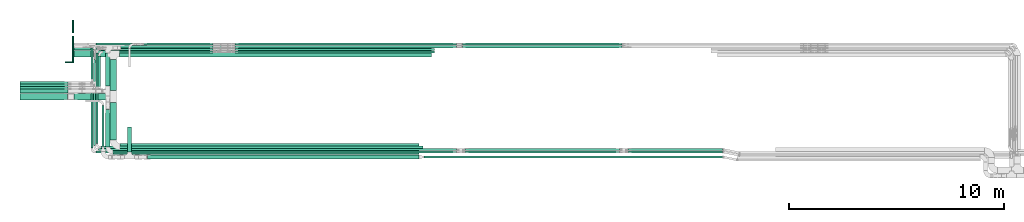
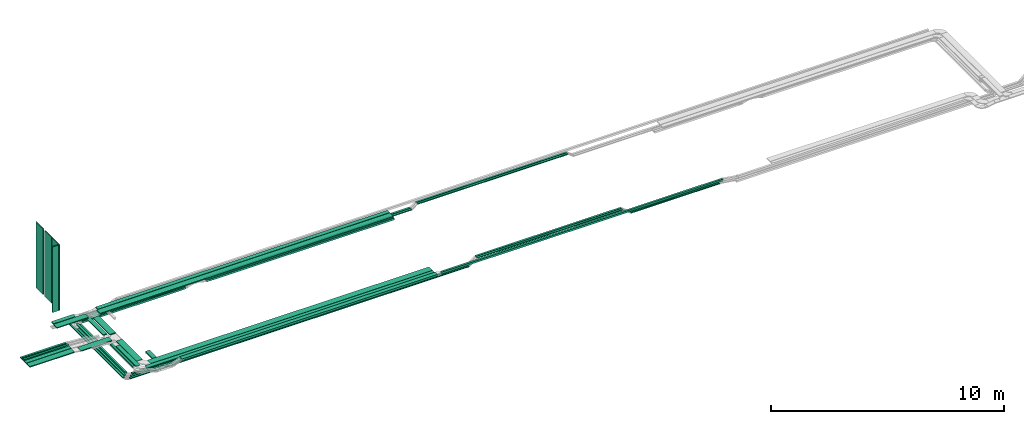
# One storey, part 1 of 19: 47 flow segments.
"""IFC2X3 building model written with IfcOpenShell, lengths in millimetres."""

from ifc_helpers import new_model, entity, si_unit, converted_unit, derived_unit, direction, frame, origin, origin_2d_with_axis, place, context, subcontext, project, spatial, rectangle, extrude, type_object, element, save


model = new_model("IFC2X3")

# Units and contexts
model_context = context("Model", 3, precision=0.01, world=origin(), true_north=direction((6.12303176911189e-17, 1.0)))
body_context = subcontext(model_context, "Body", "Model", "MODEL_VIEW")
ifc_project = project(units=[si_unit("LENGTHUNIT", "METRE", prefix="MILLI"), si_unit("AREAUNIT", "SQUARE_METRE"), si_unit("VOLUMEUNIT", "CUBIC_METRE"), converted_unit("PLANEANGLEUNIT", "DEGREE", entity("IfcRatioMeasure", 0.0174532925199433), si_unit("PLANEANGLEUNIT", "RADIAN"), dimensions=[0, 0, 0, 0, 0, 0, 0]), si_unit("MASSUNIT", "GRAM", prefix="KILO"), derived_unit("MASSDENSITYUNIT", [(si_unit("MASSUNIT", "GRAM", prefix="KILO"), 1), (si_unit("LENGTHUNIT", "METRE"), -3)]), derived_unit("MOMENTOFINERTIAUNIT", [(si_unit("LENGTHUNIT", "METRE"), 4)]), si_unit("TIMEUNIT", "SECOND"), si_unit("FREQUENCYUNIT", "HERTZ"), si_unit("THERMODYNAMICTEMPERATUREUNIT", "DEGREE_CELSIUS"), derived_unit("THERMALTRANSMITTANCEUNIT", [(si_unit("MASSUNIT", "GRAM", prefix="KILO"), 1), (si_unit("THERMODYNAMICTEMPERATUREUNIT", "KELVIN"), -1), (si_unit("TIMEUNIT", "SECOND"), -3)]), derived_unit("VOLUMETRICFLOWRATEUNIT", [(si_unit("LENGTHUNIT", "METRE"), 3), (si_unit("TIMEUNIT", "SECOND"), -1)]), derived_unit("MASSFLOWRATEUNIT", [(si_unit("MASSUNIT", "GRAM", prefix="KILO"), 1), (si_unit("TIMEUNIT", "SECOND"), -1)]), derived_unit("ROTATIONALFREQUENCYUNIT", [(si_unit("TIMEUNIT", "SECOND"), -1)]), si_unit("ELECTRICCURRENTUNIT", "AMPERE"), si_unit("ELECTRICVOLTAGEUNIT", "VOLT"), si_unit("POWERUNIT", "WATT"), si_unit("FORCEUNIT", "NEWTON", prefix="KILO"), si_unit("ILLUMINANCEUNIT", "LUX"), si_unit("LUMINOUSFLUXUNIT", "LUMEN"), si_unit("LUMINOUSINTENSITYUNIT", "CANDELA"), derived_unit("USERDEFINED", [(si_unit("MASSUNIT", "GRAM", prefix="KILO"), -1), (si_unit("LENGTHUNIT", "METRE"), -2), (si_unit("TIMEUNIT", "SECOND"), 3), (si_unit("LUMINOUSFLUXUNIT", "LUMEN"), 1)]), derived_unit("LINEARVELOCITYUNIT", [(si_unit("LENGTHUNIT", "METRE"), 1), (si_unit("TIMEUNIT", "SECOND"), -1)]), si_unit("PRESSUREUNIT", "PASCAL"), derived_unit("USERDEFINED", [(si_unit("LENGTHUNIT", "METRE"), -2), (si_unit("MASSUNIT", "GRAM", prefix="KILO"), 1), (si_unit("TIMEUNIT", "SECOND"), -2)]), derived_unit("LINEARFORCEUNIT", [(si_unit("MASSUNIT", "GRAM", prefix="KILO"), 1), (si_unit("LENGTHUNIT", "METRE"), 1), (si_unit("TIMEUNIT", "SECOND"), -2), (si_unit("LENGTHUNIT", "METRE"), -1)]), derived_unit("PLANARFORCEUNIT", [(si_unit("MASSUNIT", "GRAM", prefix="KILO"), 1), (si_unit("LENGTHUNIT", "METRE"), 1), (si_unit("TIMEUNIT", "SECOND"), -2), (si_unit("LENGTHUNIT", "METRE"), -2)])], contexts=[model_context])

# Site, building, storey
site_placement = place(None, origin())
site = spatial("IfcSite", under=ifc_project, at=site_placement, CompositionType="ELEMENT")
building_placement = place(site_placement, origin())
building = spatial("IfcBuilding", under=site, at=building_placement, CompositionType="ELEMENT")
storey_placement = place(building_placement, frame((0.0, 0.0, 12000.0)))
storey = spatial("IfcBuildingStorey", under=building, at=storey_placement, CompositionType="ELEMENT", Elevation=12000.0)

# Flow segments
cable_carrier_segment_type_1 = type_object("IfcCableCarrierSegmentType", PredefinedType="CABLETRAYSEGMENT")
flow_segment_1_placement = place(storey_placement, frame((18658.54, 14255.0, 2800.0)))
element("IfcFlowSegment", 1, at=flow_segment_1_placement, inside=storey, type_object=cable_carrier_segment_type_1, context=body_context, shape_type="SweptSolid", body=[
    extrude(rectangle(XDim=14526.5501481174, YDim=300.000000000001, at=origin_2d_with_axis()), frame((7263.28, 150.0, 0.0)), (0.0, 0.0, 1.0), 50.0000000000016),
])
flow_segment_2_placement = place(storey_placement, frame((18739.07, 14572.5, 2800.0)))
element("IfcFlowSegment", 2, at=flow_segment_2_placement, inside=storey, type_object=cable_carrier_segment_type_1, context=body_context, shape_type="SweptSolid", body=[
    extrude(rectangle(XDim=14446.0157179897, YDim=200.000000000002, at=origin_2d_with_axis()), frame((7223.01, 100.0, 0.0)), (0.0, 0.0, 1.0), 50.0000000000016),
])
flow_segment_3_placement = place(storey_placement, frame((18679.54, 9924.94, 2800.0)))
element("IfcFlowSegment", 3, at=flow_segment_3_placement, inside=storey, type_object=cable_carrier_segment_type_1, context=body_context, shape_type="SweptSolid", body=[
    extrude(rectangle(XDim=13925.5501481174, YDim=300.000000000001, at=origin_2d_with_axis()), frame((6962.78, 150.0, 0.0)), (0.0, 0.0, 1.0), 50.0000000000016),
])
flow_segment_4_placement = place(storey_placement, frame((18369.59, 9713.18, 2800.81)))
element("IfcFlowSegment", 4, at=flow_segment_4_placement, inside=storey, type_object=cable_carrier_segment_type_1, context=body_context, shape_type="SweptSolid", body=[
    extrude(rectangle(XDim=14235.499529991, YDim=200.000000000001, at=origin_2d_with_axis()), frame((7117.75, 100.0, 0.0), z_axis=(0.0, 0.0, 1.0), x_axis=(-1.0, 0.0, 0.0)), (0.0, 0.0, 1.0), 50.0000000000016),
])
flow_segment_5_placement = place(storey_placement, frame((17793.84, 14551.42, 2500.0)))
element("IfcFlowSegment", 5, at=flow_segment_5_placement, inside=storey, type_object=cable_carrier_segment_type_1, context=body_context, shape_type="SweptSolid", body=[
    extrude(rectangle(XDim=5223.92696672905, YDim=99.9999999997434, at=origin_2d_with_axis()), frame((2611.96, 50.0, 0.99), z_axis=(0.000377553079753182, 0.0, 0.999999928726834), x_axis=(0.999999928726834, 0.0, -0.000377553079753182)), (0.0, 0.0, 1.0), 99.9999999997455),
])
flow_segment_6_placement = place(storey_placement, frame((17793.86, 9996.0, 2500.0)))
element("IfcFlowSegment", 6, at=flow_segment_6_placement, inside=storey, type_object=cable_carrier_segment_type_1, context=body_context, shape_type="SweptSolid", body=[
    extrude(rectangle(XDim=14998.1629556795, YDim=99.9999999999989, at=origin_2d_with_axis()), frame((7499.08, 50.0, 0.0)), (0.0, 0.0, 1.0), 99.9999999999989),
])
flow_segment_7_placement = place(storey_placement, frame((42335.11, 9888.36, 2500.0)))
element("IfcFlowSegment", 7, at=flow_segment_7_placement, inside=storey, type_object=cable_carrier_segment_type_1, context=body_context, shape_type="SweptSolid", body=[
    extrude(rectangle(XDim=4407.91540658211, YDim=99.9999999999989, at=origin_2d_with_axis()), frame((2203.96, 50.0, 0.0)), (0.0, 0.0, 1.0), 50.0000000000016),
])
flow_segment_8_placement = place(storey_placement, frame((24039.61, 14429.99, 2500.0)))
element("IfcFlowSegment", 8, at=flow_segment_8_placement, inside=storey, type_object=cable_carrier_segment_type_1, context=body_context, shape_type="SweptSolid", body=[
    extrude(rectangle(XDim=9279.48815434617, YDim=99.9999999999989, at=origin_2d_with_axis()), frame((4639.74, 50.0, 0.0)), (0.0, 0.0, 1.0), 99.9999999999989),
])
flow_segment_9_placement = place(storey_placement, frame((17327.76, 10005.5, 2500.0)))
element("IfcFlowSegment", 9, at=flow_segment_9_placement, inside=storey, type_object=cable_carrier_segment_type_1, context=body_context, shape_type="SweptSolid", body=[
    extrude(rectangle(XDim=3038.65497752374, YDim=99.9999999999989, at=origin_2d_with_axis()), frame((50.0, 1519.33, 0.0), z_axis=(0.0, 0.0, 1.0), x_axis=(0.0, 1.0, 0.0)), (0.0, 0.0, 1.0), 50.0000000000016),
])
flow_segment_10_placement = place(storey_placement, frame((24036.73, 14792.5, 2500.0)))
element("IfcFlowSegment", 10, at=flow_segment_10_placement, inside=storey, type_object=cable_carrier_segment_type_1, context=body_context, shape_type="SweptSolid", body=[
    extrude(rectangle(XDim=10310.0487994365, YDim=99.9999999999989, at=origin_2d_with_axis()), frame((5155.02, 50.0, 0.0), z_axis=(0.0, 0.0, 1.0), x_axis=(-1.0, 0.0, 0.0)), (0.0, 0.0, 1.0), 50.0000000000016),
])
flow_segment_11_placement = place(storey_placement, frame((17557.76, 9775.5, 2500.0)))
element("IfcFlowSegment", 11, at=flow_segment_11_placement, inside=storey, type_object=cable_carrier_segment_type_1, context=body_context, shape_type="SweptSolid", body=[
    extrude(rectangle(XDim=16789.0144992146, YDim=99.9999999999989, at=origin_2d_with_axis()), frame((8394.51, 50.0, 0.0)), (0.0, 0.0, 1.0), 50.0000000000016),
])
flow_segment_12_placement = place(storey_placement, frame((17327.76, 13045.16, 2500.0)))
element("IfcFlowSegment", 12, at=flow_segment_12_placement, inside=storey, type_object=cable_carrier_segment_type_1, context=body_context, shape_type="SweptSolid", body=[
    extrude(rectangle(XDim=1617.339583353, YDim=99.9999999999989, at=origin_2d_with_axis()), frame((50.0, 808.67, 0.0), z_axis=(0.0, 0.0, 1.0), x_axis=(0.0, -1.0, 0.0)), (0.0, 0.0, 1.0), 50.0000000000016),
])
flow_segment_13_placement = place(storey_placement, frame((24036.73, 14673.63, 2500.0)))
element("IfcFlowSegment", 13, at=flow_segment_13_placement, inside=storey, type_object=cable_carrier_segment_type_1, context=body_context, shape_type="SweptSolid", body=[
    extrude(rectangle(XDim=10310.0487994361, YDim=99.9999999999989, at=origin_2d_with_axis()), frame((5155.02, 50.0, 0.0), z_axis=(0.0, 0.0, 1.0), x_axis=(-1.0, 0.0, 0.0)), (0.0, 0.0, 1.0), 50.0000000000016),
])
flow_segment_14_placement = place(storey_placement, frame((17450.8, 10118.36, 2500.0)))
element("IfcFlowSegment", 14, at=flow_segment_14_placement, inside=storey, type_object=cable_carrier_segment_type_1, context=body_context, shape_type="SweptSolid", body=[
    extrude(rectangle(XDim=2811.07814631135, YDim=99.9999999999989, at=origin_2d_with_axis()), frame((50.0, 1405.54, 0.0), z_axis=(0.0, 0.0, 1.0), x_axis=(0.0, 1.0, 0.0)), (0.0, 0.0, 1.0), 50.0000000000016),
])
flow_segment_15_placement = place(storey_placement, frame((17563.84, 10225.98, 2499.86)))
element("IfcFlowSegment", 15, at=flow_segment_15_placement, inside=storey, type_object=cable_carrier_segment_type_1, context=body_context, shape_type="SweptSolid", body=[
    extrude(rectangle(XDim=4195.41974263631, YDim=99.9999999999995, at=origin_2d_with_axis()), frame((50.0, 2097.76, 1.06), z_axis=(0.000377553037651997, -0.000495218459472091, 0.999999806106172), x_axis=(0.0, 0.999999877379314, 0.000495218494767874)), (0.0, 0.0, 1.0), 100.0),
])
flow_segment_16_placement = place(storey_placement, frame((17670.3, 12784.99, 2500.0)))
element("IfcFlowSegment", 16, at=flow_segment_16_placement, inside=storey, type_object=cable_carrier_segment_type_1, context=body_context, shape_type="SweptSolid", body=[
    extrude(rectangle(XDim=1515.00000000002, YDim=99.9999999999989, at=origin_2d_with_axis()), frame((50.0, 757.5, 0.0), z_axis=(0.0, 0.0, 1.0), x_axis=(0.0, -1.0, 0.0)), (0.0, 0.0, 1.0), 99.9999999999989),
])
flow_segment_17_placement = place(storey_placement, frame((18228.54, 10375.94, 2800.0)))
element("IfcFlowSegment", 17, at=flow_segment_17_placement, inside=storey, type_object=cable_carrier_segment_type_1, context=body_context, shape_type="SweptSolid", body=[
    extrude(rectangle(XDim=1743.84857925214, YDim=300.000000000001, at=origin_2d_with_axis()), frame((150.0, 871.92, 0.0), z_axis=(0.0, 0.0, 1.0), x_axis=(0.0, -1.0, 0.0)), (0.0, 0.0, 1.0), 50.0000000000016),
])
flow_segment_18_placement = place(storey_placement, frame((16522.31, 14255.0, 2800.0)))
element("IfcFlowSegment", 18, at=flow_segment_18_placement, inside=storey, type_object=cable_carrier_segment_type_1, context=body_context, shape_type="SweptSolid", body=[
    extrude(rectangle(XDim=300.000000000001, YDim=1576.23104262143, at=origin_2d_with_axis()), frame((788.12, 150.0, 0.0), z_axis=(0.0, 0.0, 1.0), x_axis=(0.0, -1.0, 0.0)), (0.0, 0.0, 1.0), 50.0000000000016),
])
flow_segment_19_placement = place(storey_placement, frame((16550.94, 14572.5, 2805.27)))
element("IfcFlowSegment", 19, at=flow_segment_19_placement, inside=storey, type_object=cable_carrier_segment_type_1, context=body_context, shape_type="SweptSolid", body=[
    extrude(rectangle(XDim=1069.99193836187, YDim=200.000000000002, at=origin_2d_with_axis()), frame((535.0, 100.0, 0.0), z_axis=(0.0, 0.0, 1.0), x_axis=(-1.0, 0.0, 0.0)), (0.0, 0.0, 1.0), 50.0000000000016),
])
flow_segment_20_placement = place(storey_placement, frame((18018.59, 10064.18, 2800.81)))
element("IfcFlowSegment", 20, at=flow_segment_20_placement, inside=storey, type_object=cable_carrier_segment_type_1, context=body_context, shape_type="SweptSolid", body=[
    extrude(rectangle(XDim=1739.47331484756, YDim=199.999999999998, at=origin_2d_with_axis()), frame((100.0, 869.74, 0.0), z_axis=(0.0, 0.0, 1.0), x_axis=(0.0, -1.0, 0.0)), (0.0, 0.0, 1.0), 50.0000000000016),
])
flow_segment_21_placement = place(storey_placement, frame((19026.52, 9817.45, 2628.65)))
element("IfcFlowSegment", 21, at=flow_segment_21_placement, inside=storey, type_object=cable_carrier_segment_type_1, context=body_context, shape_type="SweptSolid", body=[
    extrude(rectangle(XDim=1170.00000000001, YDim=200.000000000002, at=origin_2d_with_axis()), frame((100.0, 585.0, 0.0), z_axis=(0.0, 0.0, 1.0), x_axis=(0.0, 1.0, 0.0)), (0.0, 0.0, 1.0), 99.9999999999968),
])
flow_segment_22_placement = place(storey_placement, frame((17851.67, 10068.45, 2800.0)))
element("IfcFlowSegment", 22, at=flow_segment_22_placement, inside=storey, type_object=cable_carrier_segment_type_1, context=body_context, shape_type="SweptSolid", body=[
    extrude(rectangle(XDim=1920.94880543369, YDim=99.9999999999989, at=origin_2d_with_axis()), frame((50.0, 960.47, 0.0), z_axis=(0.0, 0.0, 1.0), x_axis=(0.0, 1.0, 0.0)), (0.0, 0.0, 1.0), 99.9999999999989),
])
flow_segment_23_placement = place(storey_placement, frame((19963.34, 9487.45, 2800.0)))
element("IfcFlowSegment", 23, at=flow_segment_23_placement, inside=storey, type_object=cable_carrier_segment_type_1, context=body_context, shape_type="SweptSolid", body=[
    extrude(rectangle(XDim=12638.7300000051, YDim=200.0, at=origin_2d_with_axis()), frame((6319.37, 100.0, 0.0)), (0.0, 0.0, 1.0), 99.9999999999989),
])
flow_segment_24_placement = place(storey_placement, frame((42335.11, 9775.5, 2500.0)))
element("IfcFlowSegment", 24, at=flow_segment_24_placement, inside=storey, type_object=cable_carrier_segment_type_1, context=body_context, shape_type="SweptSolid", body=[
    extrude(rectangle(XDim=4407.9154065821, YDim=99.9999999999989, at=origin_2d_with_axis()), frame((2203.96, 50.0, 0.0)), (0.0, 0.0, 1.0), 50.0000000000016),
])
for number, where in (
    (25, (34752.73, 9775.5, 2800.0)),
    (26, (34752.73, 9888.36, 2800.0)),
):
    element("IfcFlowSegment", number, at=place(storey_placement, frame(where)), inside=storey, type_object=cable_carrier_segment_type_1, context=body_context, shape_type="SweptSolid", body=[
        extrude(rectangle(XDim=7182.16759799779, YDim=99.9999999999989, at=origin_2d_with_axis()), frame((3591.08, 50.0, 0.0)), (0.0, 0.0, 1.0), 50.0000000000016),
    ])
flow_segment_25_placement = place(storey_placement, frame((17680.8, 9888.36, 2500.0)))
element("IfcFlowSegment", 27, at=flow_segment_25_placement, inside=storey, type_object=cable_carrier_segment_type_1, context=body_context, shape_type="SweptSolid", body=[
    extrude(rectangle(XDim=16665.9725793622, YDim=99.9999999999989, at=origin_2d_with_axis()), frame((8332.99, 50.0, 0.0)), (0.0, 0.0, 1.0), 50.0000000000016),
])
flow_segment_26_placement = place(storey_placement, frame((34624.73, 14792.5, 2700.0)))
element("IfcFlowSegment", 28, at=flow_segment_26_placement, inside=storey, type_object=cable_carrier_segment_type_1, context=body_context, shape_type="SweptSolid", body=[
    extrude(rectangle(XDim=7436.15987018975, YDim=99.9999999999989, at=origin_2d_with_axis()), frame((3718.08, 50.0, 0.0)), (0.0, 0.0, 1.0), 50.0000000000016),
])
flow_segment_27_placement = place(storey_placement, frame((34624.73, 14673.63, 2700.0)))
element("IfcFlowSegment", 29, at=flow_segment_27_placement, inside=storey, type_object=cable_carrier_segment_type_1, context=body_context, shape_type="SweptSolid", body=[
    extrude(rectangle(XDim=7436.15987018413, YDim=99.9999999999989, at=origin_2d_with_axis()), frame((3718.08, 50.0, 0.0)), (0.0, 0.0, 1.0), 50.0000000000016),
])
flow_segment_28_placement = place(storey_placement, frame((18018.59, 12888.8, 2727.85)))
element("IfcFlowSegment", 30, at=flow_segment_28_placement, inside=storey, type_object=cable_carrier_segment_type_1, context=body_context, shape_type="SweptSolid", body=[
    extrude(rectangle(XDim=1553.70113860766, YDim=199.999999999998, at=origin_2d_with_axis()), frame((100.0, 776.85, 0.0), z_axis=(0.0, 0.0, 1.0), x_axis=(0.0, -1.0, 0.0)), (0.0, 0.0, 1.0), 50.0000000000016),
])
flow_segment_29_placement = place(storey_placement, frame((16554.3, 12249.79, 2800.0)))
element("IfcFlowSegment", 31, at=flow_segment_29_placement, inside=storey, type_object=cable_carrier_segment_type_1, context=body_context, shape_type="SweptSolid", body=[
    extrude(rectangle(XDim=1544.23497765111, YDim=300.000000000001, at=origin_2d_with_axis()), frame((772.12, 150.0, 0.0), z_axis=(0.0, 0.0, 1.0), x_axis=(-1.0, 0.0, 0.0)), (0.0, 0.0, 1.0), 50.0000000000038),
])
flow_segment_30_placement = place(storey_placement, frame((18228.54, 12679.79, 2800.0)))
element("IfcFlowSegment", 32, at=flow_segment_30_placement, inside=storey, type_object=cable_carrier_segment_type_1, context=body_context, shape_type="SweptSolid", body=[
    extrude(rectangle(XDim=1445.20899434442, YDim=300.000000000001, at=origin_2d_with_axis()), frame((150.0, 722.6, 0.0), z_axis=(0.0, 0.0, 1.0), x_axis=(0.0, -1.0, 0.0)), (0.0, 0.0, 1.0), 50.0000000000016),
])
flow_segment_31_placement = place(storey_placement, frame((17557.76, 14792.5, 2500.0)))
element("IfcFlowSegment", 33, at=flow_segment_31_placement, inside=storey, type_object=cable_carrier_segment_type_1, context=body_context, shape_type="SweptSolid", body=[
    extrude(rectangle(XDim=5465.06899783628, YDim=99.9999999999989, at=origin_2d_with_axis()), frame((2732.53, 50.0, 0.0)), (0.0, 0.0, 1.0), 50.0000000000016),
])
flow_segment_32_placement = place(storey_placement, frame((17907.21, 14673.63, 2500.0)))
element("IfcFlowSegment", 34, at=flow_segment_32_placement, inside=storey, type_object=cable_carrier_segment_type_1, context=body_context, shape_type="SweptSolid", body=[
    extrude(rectangle(XDim=5115.6216378394, YDim=99.9999999999989, at=origin_2d_with_axis()), frame((2557.81, 50.0, 0.0)), (0.0, 0.0, 1.0), 50.0000000000016),
])
flow_segment_33_placement = place(storey_placement, frame((24039.61, 14551.42, 2500.0)))
element("IfcFlowSegment", 35, at=flow_segment_33_placement, inside=storey, type_object=cable_carrier_segment_type_1, context=body_context, shape_type="SweptSolid", body=[
    extrude(rectangle(XDim=9279.48815434617, YDim=99.9999999999989, at=origin_2d_with_axis()), frame((4639.74, 50.0, 0.0)), (0.0, 0.0, 1.0), 99.9999999999989),
])
flow_segment_34_placement = place(storey_placement, frame((17900.3, 14429.99, 2500.0)))
element("IfcFlowSegment", 36, at=flow_segment_34_placement, inside=storey, type_object=cable_carrier_segment_type_1, context=body_context, shape_type="SweptSolid", body=[
    extrude(rectangle(XDim=5117.52300682955, YDim=99.999999999882, at=origin_2d_with_axis()), frame((2558.76, 50.0, 0.0)), (0.0, 0.0, 1.0), 99.9999999998803),
])
flow_segment_35_placement = place(storey_placement, frame((14029.82, 12249.79, 2850.0)))
element("IfcFlowSegment", 37, at=flow_segment_35_placement, inside=storey, type_object=cable_carrier_segment_type_1, context=body_context, shape_type="SweptSolid", body=[
    extrude(rectangle(XDim=2212.51182941682, YDim=300.000000000001, at=origin_2d_with_axis()), frame((1106.26, 150.0, 0.0), z_axis=(0.0, 0.0, 1.0), x_axis=(-1.0, 0.0, 0.0)), (0.0, 0.0, 1.0), 50.0000000000038),
])
flow_segment_36_placement = place(storey_placement, frame((14029.82, 12994.16, 2850.0)))
element("IfcFlowSegment", 38, at=flow_segment_36_placement, inside=storey, type_object=cable_carrier_segment_type_1, context=body_context, shape_type="SweptSolid", body=[
    extrude(rectangle(XDim=2234.42904848946, YDim=99.9999999999989, at=origin_2d_with_axis()), frame((1117.21, 50.0, 0.0), z_axis=(0.0, 0.0, 1.0), x_axis=(-1.0, 0.0, 0.0)), (0.0, 0.0, 1.0), 50.0000000000016),
])
flow_segment_37_placement = place(storey_placement, frame((14029.82, 12879.44, 2850.0)))
element("IfcFlowSegment", 39, at=flow_segment_37_placement, inside=storey, type_object=cable_carrier_segment_type_1, context=body_context, shape_type="SweptSolid", body=[
    extrude(rectangle(XDim=2234.42904848907, YDim=99.9999999999989, at=origin_2d_with_axis()), frame((1117.21, 50.0, 0.0), z_axis=(0.0, 0.0, 1.0), x_axis=(-1.0, 0.0, 0.0)), (0.0, 0.0, 1.0), 50.0000000000016),
])
flow_segment_38_placement = place(storey_placement, frame((14029.82, 12558.8, 2850.0)))
element("IfcFlowSegment", 40, at=flow_segment_38_placement, inside=storey, type_object=cable_carrier_segment_type_1, context=body_context, shape_type="SweptSolid", body=[
    extrude(rectangle(XDim=2234.42904848929, YDim=200.000000000002, at=origin_2d_with_axis()), frame((1117.21, 100.0, 0.0), z_axis=(0.0, 0.0, 1.0), x_axis=(-1.0, 0.0, 0.0)), (0.0, 0.0, 1.0), 50.0000000000038),
])
flow_segment_39_placement = place(storey_placement, frame((14029.82, 12764.16, 2850.0)))
element("IfcFlowSegment", 41, at=flow_segment_39_placement, inside=storey, type_object=cable_carrier_segment_type_1, context=body_context, shape_type="SweptSolid", body=[
    extrude(rectangle(XDim=2233.4822475641, YDim=99.9999999999989, at=origin_2d_with_axis()), frame((1116.74, 50.0, 0.0), z_axis=(0.0, 0.0, 1.0), x_axis=(-1.0, 0.0, 0.0)), (0.0, 0.0, 1.0), 99.9999999999989),
])
flow_segment_40_placement = place(storey_placement, frame((17450.8, 12930.44, 2500.0)))
element("IfcFlowSegment", 42, at=flow_segment_40_placement, inside=storey, type_object=cable_carrier_segment_type_1, context=body_context, shape_type="SweptSolid", body=[
    extrude(rectangle(XDim=1191.68964176684, YDim=99.9999999999989, at=origin_2d_with_axis()), frame((50.0, 595.84, 0.0), z_axis=(0.0, 0.0, 1.0), x_axis=(0.0, 1.0, 0.0)), (0.0, 0.0, 1.0), 50.0000000000016),
])
flow_segment_41_placement = place(storey_placement, frame((32832.07, 9537.45, 2800.0)))
element("IfcFlowSegment", 43, at=flow_segment_41_placement, inside=storey, type_object=cable_carrier_segment_type_1, context=body_context, shape_type="SweptSolid", body=[
    extrude(rectangle(XDim=13917.9501795946, YDim=100.000000000001, at=origin_2d_with_axis()), frame((6958.98, 50.0, 0.0)), (0.0, 0.0, 1.0), 99.9999999999989),
])
cable_carrier_segment_type_2 = type_object("IfcCableCarrierSegmentType", PredefinedType="CABLETRAYSEGMENT")
for number, where in (
    (44, (16472.31, 15367.61, 3925.84)),
    (45, (16472.31, 14607.61, 3925.84)),
):
    element("IfcFlowSegment", number, at=place(storey_placement, frame(where)), inside=storey, type_object=cable_carrier_segment_type_2, context=body_context, shape_type="SweptSolid", body=[
        extrude(rectangle(XDim=50.0000000000016, YDim=600.000000000002, at=origin_2d_with_axis()), frame((25.0, 300.0, 0.0), z_axis=(0.0, 0.0, 1.0), x_axis=(-1.0, 0.0, 0.0)), (0.0, 0.0, 1.0), 3440.0),
    ])
flow_segment_42_placement = place(storey_placement, frame((16472.31, 13987.61, 3925.84)))
element("IfcFlowSegment", 46, at=flow_segment_42_placement, inside=storey, type_object=cable_carrier_segment_type_2, context=body_context, shape_type="SweptSolid", body=[
    extrude(rectangle(XDim=50.0000000000016, YDim=599.999999999998, at=origin_2d_with_axis()), frame((25.0, 300.0, 0.0), z_axis=(0.0, 0.0, 1.0), x_axis=(-1.0, 0.0, 0.0)), (0.0, 0.0, 1.0), 3440.00000000001),
])
flow_segment_43_placement = place(storey_placement, frame((16147.31, 13982.61, 3925.84)))
element("IfcFlowSegment", 47, at=flow_segment_43_placement, inside=storey, type_object=cable_carrier_segment_type_2, context=body_context, shape_type="SweptSolid", body=[
    extrude(rectangle(XDim=50.0000000000016, YDim=300.000000000001, at=origin_2d_with_axis()), frame((150.0, 25.0, 0.0), z_axis=(0.0, 0.0, 1.0), x_axis=(0.0, 1.0, 0.0)), (0.0, 0.0, 1.0), 3440.00000000001),
])

save(model, "model.ifc")
